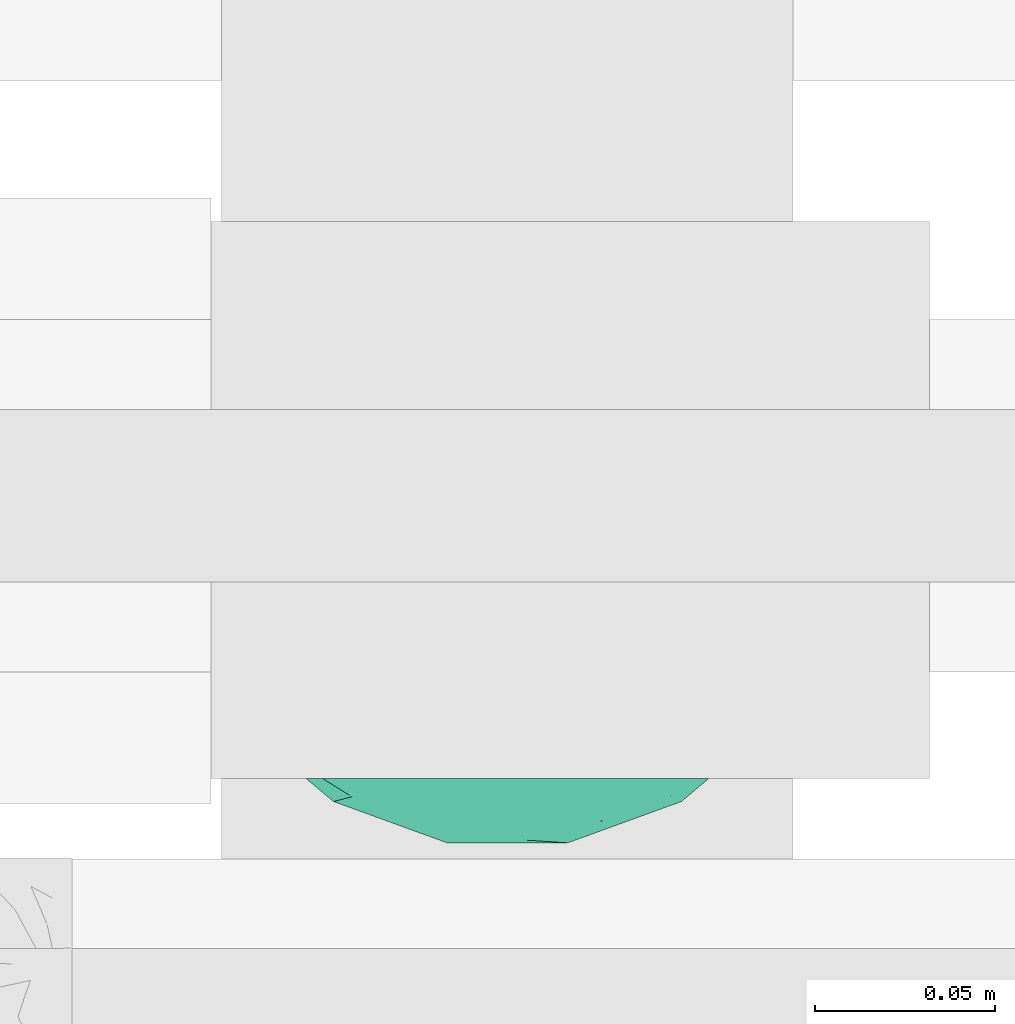
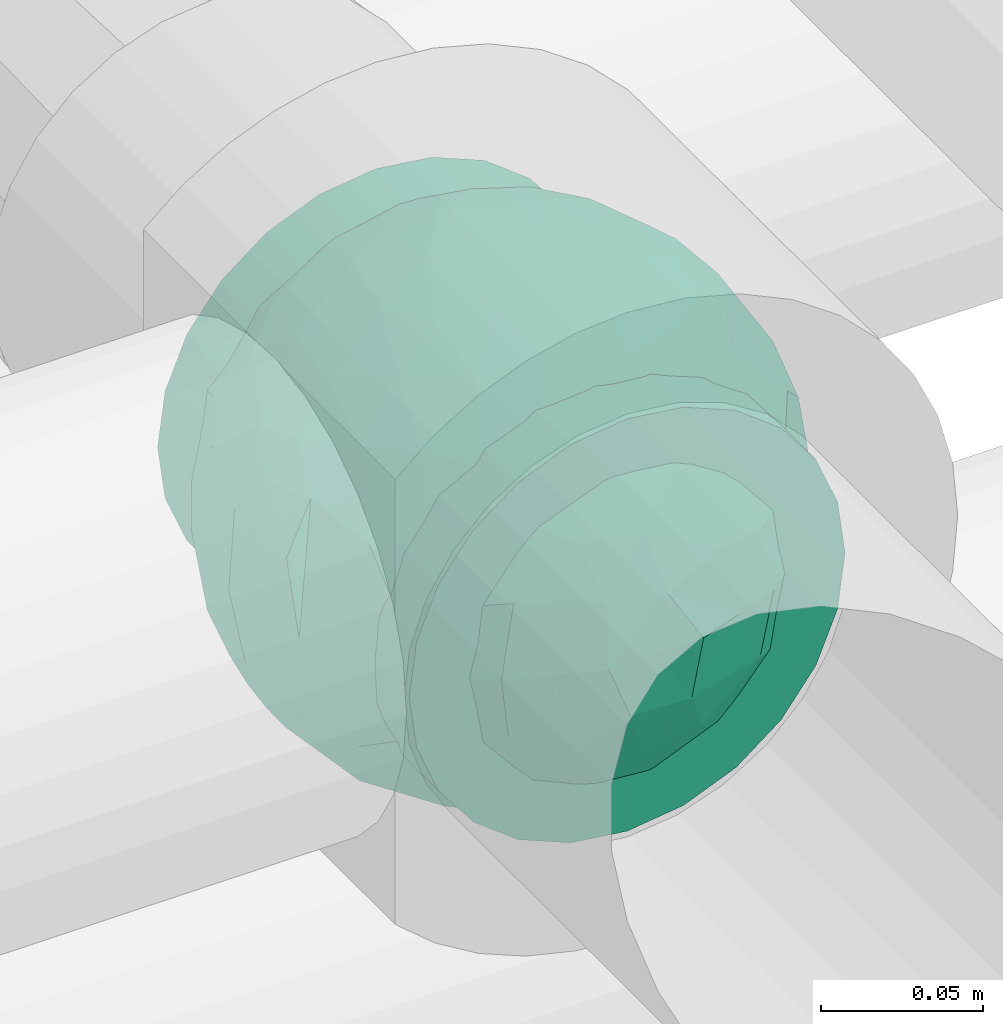
# One storey, part 66 of 93: 1 flow fitting.
"""IFC2X3 building model written with IfcOpenShell, lengths in millimetres."""

from ifc_helpers import new_model, entity, si_unit, converted_unit, derived_unit, direction, frame, origin, place, context, subcontext, project, spatial, faceted_brep, source, transform, mapped, material, material_list, type_object, type_shapes, element, save


model = new_model("IFC2X3")

# Units and contexts
model_context = context("Model", 3, precision=0.01, world=origin(), true_north=direction((6.12303176911189e-17, 1.0)))
body_context = subcontext(model_context, "Body", "Model", "MODEL_VIEW")
ifc_project = project(units=[si_unit("LENGTHUNIT", "METRE", prefix="MILLI"), si_unit("AREAUNIT", "SQUARE_METRE"), si_unit("VOLUMEUNIT", "CUBIC_METRE"), converted_unit("PLANEANGLEUNIT", "DEGREE", entity("IfcRatioMeasure", 0.0174532925199433), si_unit("PLANEANGLEUNIT", "RADIAN"), dimensions=[0, 0, 0, 0, 0, 0, 0]), si_unit("MASSUNIT", "GRAM", prefix="KILO"), derived_unit("MASSDENSITYUNIT", [(si_unit("MASSUNIT", "GRAM", prefix="KILO"), 1), (si_unit("LENGTHUNIT", "METRE"), -3)]), derived_unit("MOMENTOFINERTIAUNIT", [(si_unit("LENGTHUNIT", "METRE"), 4)]), si_unit("TIMEUNIT", "SECOND"), si_unit("FREQUENCYUNIT", "HERTZ"), si_unit("THERMODYNAMICTEMPERATUREUNIT", "DEGREE_CELSIUS"), derived_unit("THERMALTRANSMITTANCEUNIT", [(si_unit("MASSUNIT", "GRAM", prefix="KILO"), 1), (si_unit("THERMODYNAMICTEMPERATUREUNIT", "KELVIN"), -1), (si_unit("TIMEUNIT", "SECOND"), -3)]), derived_unit("VOLUMETRICFLOWRATEUNIT", [(si_unit("LENGTHUNIT", "METRE"), 3), (si_unit("TIMEUNIT", "SECOND"), -1)]), derived_unit("MASSFLOWRATEUNIT", [(si_unit("MASSUNIT", "GRAM", prefix="KILO"), 1), (si_unit("TIMEUNIT", "SECOND"), -1)]), derived_unit("ROTATIONALFREQUENCYUNIT", [(si_unit("TIMEUNIT", "SECOND"), -1)]), si_unit("ELECTRICCURRENTUNIT", "AMPERE"), si_unit("ELECTRICVOLTAGEUNIT", "VOLT"), si_unit("POWERUNIT", "WATT"), si_unit("FORCEUNIT", "NEWTON", prefix="KILO"), si_unit("ILLUMINANCEUNIT", "LUX"), si_unit("LUMINOUSFLUXUNIT", "LUMEN"), si_unit("LUMINOUSINTENSITYUNIT", "CANDELA"), derived_unit("USERDEFINED", [(si_unit("MASSUNIT", "GRAM", prefix="KILO"), -1), (si_unit("LENGTHUNIT", "METRE"), -2), (si_unit("TIMEUNIT", "SECOND"), 3), (si_unit("LUMINOUSFLUXUNIT", "LUMEN"), 1)]), derived_unit("LINEARVELOCITYUNIT", [(si_unit("LENGTHUNIT", "METRE"), 1), (si_unit("TIMEUNIT", "SECOND"), -1)]), si_unit("PRESSUREUNIT", "PASCAL"), derived_unit("USERDEFINED", [(si_unit("LENGTHUNIT", "METRE"), -2), (si_unit("MASSUNIT", "GRAM", prefix="KILO"), 1), (si_unit("TIMEUNIT", "SECOND"), -2)]), derived_unit("LINEARFORCEUNIT", [(si_unit("MASSUNIT", "GRAM", prefix="KILO"), 1), (si_unit("LENGTHUNIT", "METRE"), 1), (si_unit("TIMEUNIT", "SECOND"), -2), (si_unit("LENGTHUNIT", "METRE"), -1)]), derived_unit("PLANARFORCEUNIT", [(si_unit("MASSUNIT", "GRAM", prefix="KILO"), 1), (si_unit("LENGTHUNIT", "METRE"), 1), (si_unit("TIMEUNIT", "SECOND"), -2), (si_unit("LENGTHUNIT", "METRE"), -2)])], contexts=[model_context])

# Site, building, storey
site_placement = place(None, origin())
site = spatial("IfcSite", under=ifc_project, at=site_placement, CompositionType="ELEMENT")
building_placement = place(site_placement, origin())
building = spatial("IfcBuilding", under=site, at=building_placement, CompositionType="ELEMENT")
storey_placement = place(building_placement, frame((0.0, 0.0, -4200.0)))
storey = spatial("IfcBuildingStorey", under=building, at=storey_placement, CompositionType="ELEMENT", Elevation=-4200.0)

# Flow fitting
ifc_material_1 = material()
ifc_material_2 = material(Name="ADSK_")
ifc_material_list = material_list([ifc_material_1, ifc_material_2])
pipe_fitting_type = type_object("IfcPipeFittingType", Name="ADSK_2", PredefinedType="NOTDEFINED", material=ifc_material_list)
shared_shape = source(origin(), body_context, "Body", "Brep", [
    faceted_brep([(-77.5, 38.75, -67.12), (-77.5, 20.06, -74.86), (-77.5, 0.0, -77.5), (-77.5, -20.06, -74.86), (-77.5, -38.75, -67.12), (-77.5, -54.8, -54.8), (-77.5, -67.12, -38.75), (-77.5, -70.99, -29.4), (-77.5, -74.86, -20.06), (-77.5, -76.18, -10.03), (-77.5, -77.5, 0.0), (-77.5, -76.18, 10.03), (-77.5, -74.86, 20.06), (-77.5, -70.99, 29.4), (-77.5, -67.12, 38.75), (-77.5, -54.8, 54.8), (-77.5, -38.75, 67.12), (-77.5, -20.06, 74.86), (-77.5, 0.0, 77.5), (-77.5, 20.06, 74.86), (-77.5, 38.75, 67.12), (-77.5, 54.8, 54.8), (-77.5, 67.12, 38.75), (-77.5, 74.86, 20.06), (-77.5, 77.5, 0.0), (-77.5, 74.86, -20.06), (-77.5, 67.12, -38.75), (-77.5, 54.8, -54.8), (77.5, 0.0, -77.5), (77.5, 20.06, -74.86), (77.5, 38.75, -67.12), (77.5, 54.8, -54.8), (77.5, 67.12, -38.75), (77.5, 74.86, -20.06), (77.5, 77.5, 0.0), (77.5, 74.86, 20.06), (77.5, 67.12, 38.75), (77.5, 54.8, 54.8), (77.5, 38.75, 67.12), (77.5, 20.06, 74.86), (77.5, 0.0, 77.5), (77.5, -20.06, 74.86), (77.5, -38.75, 67.12), (77.5, -54.8, 54.8), (77.5, -67.12, 38.75), (77.5, -70.99, 29.4), (77.5, -74.86, 20.06), (77.5, -76.18, 10.03), (77.5, -77.5, 0.0), (77.5, -76.18, -10.03), (77.5, -74.86, -20.06), (77.5, -70.99, -29.4), (77.5, -67.12, -38.75), (77.5, -54.8, -54.8), (77.5, -38.75, -67.12), (77.5, -20.06, -74.86), (39.85, -76.08, 14.76), (41.18, -76.79, 7.38), (32.47, -72.49, 27.42), (36.16, -74.28, 21.09), (7.52, -65.24, 41.83), (42.5, -77.5, 0.0), (21.39, -68.25, 36.72), (14.46, -66.74, 39.28), (-21.4, -68.25, 36.72), (-32.48, -72.49, 27.41), (-39.86, -76.08, 14.76), (-41.18, -76.79, 7.38), (-42.5, -77.5, 0.0), (-36.17, -74.29, 21.08), (-14.46, -66.75, 39.27), (-7.53, -65.24, 41.83), (-0.01, -65.24, 41.83), (7.52, -65.24, -41.83), (-41.18, -76.79, -7.38), (21.39, -68.25, -36.72), (14.46, -66.74, -39.28), (41.18, -76.79, -7.38), (-39.86, -76.08, -14.76), (39.85, -76.08, -14.76), (36.16, -74.28, -21.09), (32.47, -72.49, -27.42), (-7.53, -65.24, -41.83), (-14.46, -66.75, -39.27), (-21.4, -68.25, -36.72), (-32.48, -72.49, -27.41), (-0.01, -65.24, -41.83), (-36.17, -74.29, -21.08), (11.0, -82.5, -41.05), (21.25, -82.5, -36.81), (30.05, -82.5, -30.05), (36.81, -82.5, -21.25), (41.05, -82.5, -11.0), (41.78, -82.5, -5.5), (42.5, -82.5, 0.0), (41.78, -82.5, 5.5), (41.05, -82.5, 11.0), (36.81, -82.5, 21.25), (30.05, -82.5, 30.05), (21.25, -82.5, 36.81), (11.0, -82.5, 41.05), (0.0, -82.5, 42.5), (-11.0, -82.5, 41.05), (-21.25, -82.5, 36.81), (-30.05, -82.5, 30.05), (-36.81, -82.5, 21.25), (-41.05, -82.5, 11.0), (-41.78, -82.5, 5.5), (-42.5, -82.5, 0.0), (-41.78, -82.5, -5.5), (-41.05, -82.5, -11.0), (-36.81, -82.5, -21.25), (-30.05, -82.5, -30.05), (-21.25, -82.5, -36.81), (-11.0, -82.5, -41.05), (0.0, -82.5, -42.5)], [[[0, 1, 2, 3, 4, 5, 6, 7, 8, 9, 10, 11, 12, 13, 14, 15, 16, 17, 18, 19, 20, 21, 22, 23, 24, 25, 26, 27]], [[28, 29, 30, 31, 32, 33, 34, 35, 36, 37, 38, 39, 40, 41, 42, 43, 44, 45, 46, 47, 48, 49, 50, 51, 52, 53, 54, 55]], [[47, 46, 56]], [[48, 47, 57]], [[46, 58, 59, 56]], [[44, 43, 60]], [[48, 57, 61]], [[58, 45, 62]], [[44, 60, 63, 62]], [[47, 56, 57]], [[43, 15, 60]], [[62, 45, 44]], [[64, 13, 65]], [[66, 11, 67]], [[68, 67, 10]], [[12, 66, 69, 65]], [[14, 64, 70, 71]], [[58, 46, 45]], [[14, 13, 64]], [[14, 71, 15]], [[65, 13, 12]], [[15, 71, 72, 60]], [[10, 67, 11]], [[66, 12, 11]], [[43, 42, 16, 15]], [[18, 17, 41, 40]], [[17, 16, 42, 41]], [[19, 18, 40, 39]], [[36, 35, 23, 22]], [[21, 20, 38, 37]], [[22, 21, 37, 36]], [[39, 38, 20, 19]], [[24, 23, 35, 34]], [[26, 25, 33, 32]], [[25, 24, 34, 33]], [[27, 26, 32, 31]], [[28, 55, 3, 2]], [[1, 0, 30, 29]], [[2, 1, 29, 28]], [[31, 30, 0, 27]], [[4, 3, 55, 54]], [[54, 53, 5, 4]], [[53, 52, 73]], [[10, 74, 68]], [[52, 75, 76, 73]], [[51, 75, 52]], [[53, 73, 5]], [[61, 77, 48]], [[9, 78, 74]], [[50, 79, 80, 81]], [[79, 49, 77]], [[75, 51, 81]], [[50, 81, 51]], [[6, 82, 83, 84]], [[85, 8, 7]], [[6, 5, 82]], [[85, 7, 84]], [[5, 73, 86, 82]], [[8, 85, 87, 78]], [[79, 50, 49]], [[78, 9, 8]], [[74, 10, 9]], [[48, 77, 49]], [[7, 6, 84]], [[88, 89, 90, 91, 92, 93, 94, 95, 96, 97, 98, 99, 100, 101, 102, 103, 104, 105, 106, 107, 108, 109, 110, 111, 112, 113, 114, 115]], [[107, 106, 67]], [[65, 105, 104]], [[106, 105, 66]], [[104, 103, 64]], [[61, 95, 94]], [[107, 68, 108]], [[66, 105, 65, 69]], [[70, 64, 103]], [[64, 65, 104]], [[101, 60, 72, 71]], [[102, 71, 70]], [[102, 70, 103]], [[68, 107, 67]], [[57, 96, 95]], [[60, 101, 100]], [[101, 71, 102]], [[58, 98, 97]], [[99, 98, 62]], [[56, 97, 96]], [[99, 63, 100]], [[98, 58, 62]], [[106, 66, 67]], [[63, 60, 100]], [[96, 57, 56]], [[59, 58, 97, 56]], [[95, 61, 57]], [[63, 99, 62]], [[93, 92, 77]], [[81, 91, 90]], [[92, 91, 79]], [[90, 89, 75]], [[68, 109, 108]], [[93, 61, 94]], [[79, 91, 81, 80]], [[76, 75, 89]], [[75, 81, 90]], [[115, 82, 86, 73]], [[83, 113, 84]], [[88, 76, 89]], [[88, 73, 76]], [[61, 93, 77]], [[82, 115, 114]], [[115, 73, 88]], [[111, 85, 112]], [[74, 110, 109]], [[113, 112, 84]], [[78, 111, 110]], [[113, 83, 114]], [[112, 85, 84]], [[92, 79, 77]], [[110, 74, 78]], [[87, 85, 111, 78]], [[109, 68, 74]], [[83, 82, 114]]]),
    faceted_brep([(74.09, -36.62, -50.54), (86.5, -25.35, -35.5), (82.61, -45.18, -22.81), (-16.75, -33.7, -89.27), (0.0, -42.78, -86.92), (-23.87, -49.97, -79.49), (73.94, -14.61, -60.86), (53.84, -28.63, -75.28), (-16.57, 93.95, 0.0), (-18.09, 86.11, -40.53), (-32.84, 86.73, -28.0), (-44.04, -10.15, -85.69), (-19.2, 4.88, -94.83), (-22.92, -15.62, -92.82), (89.65, 32.63, 0.0), (82.61, 44.34, -24.37), (83.9, 48.44, 0.0), (47.7, -82.62, 0.0), (60.26, -69.94, -29.38), (62.27, -74.21, 0.0), (95.4, 0.0, 0.0), (95.4, -16.82, 0.0), (94.13, -8.44, -21.26), (93.14, 13.95, -22.71), (95.4, 16.82, 0.0), (76.54, 8.21, -58.81), (74.09, 36.62, -50.54), (84.96, 22.7, -40.64), (28.25, -36.42, -85.21), (19.67, -61.78, -71.98), (-67.45, 51.53, -46.69), (-45.73, 54.97, -65.36), (-59.68, 42.12, -63.64), (47.7, 82.62, 0.0), (62.27, 74.21, 0.0), (59.48, 63.11, -43.18), (-48.12, -74.69, -38.62), (-33.13, -91.03, 0.0), (-47.7, -82.62, 0.0), (72.35, 57.3, -29.46), (60.01, 43.15, -62.62), (62.52, -52.48, -52.18), (45.73, -54.97, -65.36), (-62.27, -74.21, 0.0), (-73.08, -61.32, 0.0), (-72.41, -59.62, -24.21), (7.26, -81.07, -52.53), (35.35, -68.17, -59.06), (27.87, -86.63, -33.22), (-74.09, -36.62, -50.54), (-84.35, -21.79, -42.37), (-76.59, -6.33, -58.98), (61.55, 0.0, -74.81), (-61.55, 0.0, -74.81), (-79.37, 15.54, -53.33), (-95.4, -16.82, 0.0), (-92.58, -16.52, -23.25), (-89.65, -32.63, 0.0), (63.81, 22.67, -69.28), (-18.69, 68.07, -66.35), (-42.94, 76.94, -40.26), (-74.09, 36.62, -50.54), (-43.64, 36.19, -78.55), (-65.1, 21.71, -68.38), (44.46, 15.06, -84.74), (-65.04, -21.76, -68.42), (-94.63, 4.93, -20.13), (-87.93, 0.0, -40.67), (-89.65, 32.63, 0.0), (-89.27, 26.35, -26.85), (27.96, 84.78, -37.61), (7.26, 81.07, -52.53), (1.19, 92.73, -28.0), (3.41, -92.84, -27.46), (-8.28, -95.41, 0.0), (-11.9, -93.14, -23.83), (73.08, 61.32, 0.0), (87.93, 0.0, -40.67), (73.08, -61.32, 0.0), (83.9, -48.44, 0.0), (-73.08, 61.32, 0.0), (-82.24, 45.34, -23.77), (-83.9, 48.44, 0.0), (-63.57, -59.47, -42.5), (-45.73, -54.97, -65.36), (-82.58, -43.28, -26.32), (29.11, 48.1, -78.89), (45.73, 54.97, -65.36), (44.58, 36.0, -78.11), (-61.2, 65.56, -36.61), (-6.93, -65.5, -71.03), (30.56, -5.14, -91.79), (9.54, -19.86, -94.34), (0.0, 12.89, -96.01), (47.81, -10.83, -83.56), (89.65, -32.63, 0.0), (44.95, 76.64, -38.61), (33.13, 91.03, 0.0), (28.53, 69.09, -61.62), (-51.45, 14.65, -80.76), (22.17, 26.71, -90.44), (33.13, -91.03, 0.0), (44.95, -76.64, -38.61), (72.35, -57.3, -29.46), (16.57, -93.95, 0.0), (-15.25, 22.47, -92.99), (2.72, 32.92, -91.07), (8.92, 50.75, -82.03), (9.42, 67.57, -68.78), (16.57, 93.95, 0.0), (-5.45, -87.35, -41.54), (8.28, -95.41, 0.0), (0.0, -96.88, 0.0), (-24.34, -90.45, -24.71), (-25.14, -82.23, -44.62), (-16.57, -93.95, 0.0), (-9.92, -78.26, -56.23), (-30.26, -67.58, -62.46), (-40.87, -32.58, -81.57), (-34.66, 17.97, -88.66), (-59.69, -42.16, -63.59), (-16.8, 39.61, -86.8), (-28.19, 53.95, -75.36), (-10.32, 55.25, -78.9), (-57.91, -73.21, -25.92), (-83.9, -48.44, 0.0), (-95.4, 0.0, 0.0), (-95.4, 16.82, 0.0), (-72.43, 58.81, -26.08), (-62.27, 74.21, 0.0), (-47.7, 82.62, 0.0), (-33.13, 91.03, 0.0), (0.0, 96.87, 0.0), (-74.09, -36.62, 50.54), (-86.5, -25.35, 35.5), (-82.61, -45.18, 22.81), (16.75, -33.7, 89.27), (0.0, -42.78, 86.92), (23.87, -49.97, 79.49), (-73.94, -14.61, 60.86), (-53.84, -28.63, 75.28), (18.09, 86.11, 40.53), (32.84, 86.73, 28.0), (44.04, -10.15, 85.69), (19.2, 4.88, 94.83), (22.92, -15.62, 92.82), (-82.61, 44.34, 24.37), (-60.26, -69.94, 29.38), (-94.13, -8.44, 21.26), (-93.14, 13.95, 22.71), (-76.54, 8.21, 58.81), (-74.09, 36.62, 50.54), (-84.96, 22.7, 40.64), (-28.25, -36.42, 85.21), (-19.67, -61.78, 71.98), (67.45, 51.53, 46.69), (45.73, 54.97, 65.36), (59.68, 42.12, 63.64), (-28.53, 69.09, 61.62), (-45.73, 54.97, 65.36), (-29.11, 48.1, 78.89), (48.12, -74.69, 38.62), (-59.48, 63.11, 43.18), (-72.35, 57.3, 29.46), (-60.01, 43.15, 62.62), (-35.35, -68.17, 59.06), (-7.26, -81.07, 52.53), (72.41, -59.62, 24.21), (-3.41, -92.84, 27.46), (74.09, -36.62, 50.54), (84.35, -21.79, 42.37), (76.59, -6.33, 58.98), (-61.55, 0.0, 74.81), (61.55, 0.0, 74.81), (79.37, 15.54, 53.33), (92.58, -16.52, 23.25), (-63.81, 22.67, 69.28), (18.69, 68.07, 66.35), (42.94, 76.94, 40.26), (74.09, 36.62, 50.54), (43.64, 36.19, 78.55), (65.1, 21.71, 68.38), (-44.46, 15.06, 84.74), (65.04, -21.76, 68.42), (94.63, 4.93, 20.13), (87.93, 0.0, 40.67), (89.27, 26.35, 26.85), (-27.96, 84.78, 37.61), (-7.26, 81.07, 52.53), (-1.19, 92.73, 28.0), (11.9, -93.14, 23.83), (-87.93, 0.0, 40.67), (82.24, 45.34, 23.77), (63.57, -59.47, 42.5), (45.73, -54.97, 65.36), (82.58, -43.28, 26.32), (-44.58, 36.0, 78.11), (61.2, 65.56, 36.61), (25.14, -82.23, 44.62), (5.45, -87.35, 41.54), (24.34, -90.45, 24.71), (6.93, -65.5, 71.03), (-30.56, -5.14, 91.79), (-9.54, -19.86, 94.34), (0.0, 12.89, 96.01), (-47.81, -10.83, 83.56), (-44.95, 76.64, 38.61), (51.45, 14.65, 80.76), (-62.52, -52.48, 52.18), (-45.73, -54.97, 65.36), (-22.17, 26.71, 90.44), (-44.95, -76.64, 38.61), (-72.35, -57.3, 29.46), (-27.87, -86.63, 33.22), (15.25, 22.47, 92.99), (-2.72, 32.92, 91.07), (-8.92, 50.75, 82.03), (-9.42, 67.57, 68.78), (9.92, -78.26, 56.23), (30.26, -67.58, 62.46), (40.87, -32.58, 81.57), (34.66, 17.97, 88.66), (59.69, -42.16, 63.59), (16.8, 39.61, 86.8), (28.19, 53.95, 75.36), (10.32, 55.25, 78.9), (57.91, -73.21, 25.92), (72.43, 58.81, 26.08)], [[[0, 1, 2]], [[3, 4, 5]], [[6, 0, 7]], [[8, 9, 10]], [[11, 12, 13]], [[14, 15, 16]], [[17, 18, 19]], [[20, 21, 22]], [[23, 24, 20]], [[25, 26, 27]], [[4, 28, 29]], [[30, 31, 32]], [[33, 34, 35]], [[36, 37, 38]], [[35, 39, 40]], [[41, 18, 42]], [[43, 44, 45]], [[46, 47, 48]], [[49, 50, 51]], [[52, 25, 6]], [[53, 51, 54]], [[55, 56, 57]], [[26, 25, 58]], [[59, 31, 60]], [[32, 61, 30]], [[62, 63, 32]], [[52, 64, 58]], [[51, 65, 49]], [[56, 66, 67]], [[66, 68, 69]], [[70, 71, 72]], [[73, 74, 75]], [[6, 7, 52]], [[20, 22, 23]], [[76, 39, 34]], [[15, 26, 39]], [[1, 77, 22]], [[78, 2, 79]], [[61, 54, 69]], [[80, 81, 82]], [[36, 83, 84]], [[85, 56, 50]], [[86, 87, 88]], [[60, 31, 89]], [[48, 73, 46]], [[4, 29, 90]], [[91, 92, 93]], [[7, 94, 52]], [[77, 23, 22]], [[95, 79, 2]], [[0, 6, 1]], [[1, 22, 95]], [[1, 95, 2]], [[27, 23, 77]], [[15, 14, 23]], [[25, 27, 77]], [[15, 76, 16]], [[40, 39, 26]], [[39, 76, 15]], [[96, 97, 33]], [[70, 98, 71]], [[39, 35, 34]], [[87, 86, 98]], [[77, 1, 6]], [[25, 52, 58]], [[62, 99, 63]], [[26, 15, 27]], [[6, 25, 77]], [[0, 41, 7]], [[42, 28, 7]], [[92, 91, 28]], [[94, 28, 91]], [[88, 87, 40]], [[52, 94, 64]], [[40, 26, 58]], [[100, 91, 93]], [[88, 40, 58]], [[22, 21, 95]], [[101, 102, 17]], [[103, 78, 19]], [[41, 0, 103]], [[18, 102, 42]], [[101, 48, 102]], [[101, 104, 48]], [[29, 28, 42]], [[28, 4, 92]], [[102, 47, 42]], [[90, 29, 46]], [[88, 58, 64]], [[40, 87, 35]], [[87, 96, 35]], [[33, 35, 96]], [[100, 64, 91]], [[88, 64, 100]], [[12, 105, 93]], [[98, 96, 87]], [[106, 100, 93]], [[86, 100, 107]], [[100, 86, 88]], [[98, 108, 71]], [[108, 86, 107]], [[109, 70, 72]], [[70, 109, 97]], [[96, 98, 70]], [[97, 96, 70]], [[78, 103, 2]], [[0, 2, 103]], [[41, 103, 18]], [[7, 41, 42]], [[19, 18, 103]], [[102, 18, 17]], [[75, 110, 73]], [[73, 104, 111, 112]], [[113, 114, 110]], [[115, 75, 74]], [[36, 114, 37]], [[90, 5, 4]], [[73, 48, 104]], [[47, 46, 29]], [[46, 116, 90]], [[5, 117, 84]], [[90, 116, 117]], [[118, 13, 3]], [[118, 5, 84]], [[11, 119, 12]], [[65, 120, 49]], [[11, 13, 118]], [[63, 53, 54]], [[121, 122, 123]], [[90, 117, 5]], [[49, 120, 83]], [[117, 36, 84]], [[36, 117, 114]], [[43, 45, 124]], [[38, 124, 36]], [[83, 124, 45]], [[85, 125, 57]], [[125, 85, 44]], [[45, 49, 83]], [[66, 55, 126, 127]], [[57, 56, 85]], [[56, 67, 50]], [[51, 50, 67]], [[85, 50, 49]], [[54, 51, 67]], [[51, 53, 65]], [[69, 54, 67]], [[54, 61, 63]], [[69, 67, 66]], [[128, 129, 89]], [[11, 65, 53]], [[120, 118, 84]], [[32, 63, 61]], [[99, 53, 63]], [[118, 120, 65]], [[83, 120, 84]], [[129, 128, 80]], [[62, 32, 31]], [[60, 130, 131]], [[130, 60, 89]], [[9, 71, 59]], [[10, 60, 131]], [[108, 59, 71]], [[71, 9, 72]], [[62, 121, 119]], [[122, 59, 123]], [[62, 119, 99]], [[62, 31, 122]], [[106, 107, 100]], [[44, 85, 45]], [[49, 45, 85]], [[55, 66, 56]], [[62, 122, 121]], [[89, 129, 130]], [[65, 11, 118]], [[11, 53, 99]], [[80, 128, 81]], [[30, 128, 89]], [[81, 61, 69]], [[61, 81, 128]], [[82, 81, 69]], [[10, 59, 60]], [[72, 8, 132]], [[8, 72, 9]], [[109, 72, 132]], [[3, 92, 4]], [[92, 13, 12]], [[23, 27, 15]], [[14, 24, 23]], [[11, 99, 119]], [[128, 30, 61]], [[31, 30, 89]], [[28, 94, 7]], [[64, 94, 91]], [[48, 47, 102]], [[29, 42, 47]], [[105, 106, 93]], [[123, 106, 121]], [[86, 108, 98]], [[108, 107, 123]], [[73, 112, 74]], [[113, 75, 115]], [[114, 116, 110]], [[115, 37, 113]], [[37, 114, 113]], [[46, 73, 110]], [[117, 116, 114]], [[110, 75, 113]], [[46, 110, 116]], [[118, 3, 5]], [[92, 3, 13]], [[105, 119, 121]], [[92, 12, 93]], [[119, 105, 12]], [[106, 105, 121]], [[43, 124, 38]], [[83, 36, 124]], [[68, 66, 127]], [[68, 82, 69]], [[31, 59, 122]], [[108, 123, 59]], [[106, 123, 107]], [[8, 10, 131]], [[59, 10, 9]], [[133, 134, 135]], [[136, 137, 138]], [[139, 133, 140]], [[109, 141, 142]], [[143, 144, 145]], [[68, 146, 82]], [[38, 147, 43]], [[148, 126, 55]], [[149, 127, 126]], [[150, 151, 152]], [[137, 153, 154]], [[155, 156, 157]], [[158, 159, 160]], [[161, 101, 17]], [[162, 163, 164]], [[154, 165, 166]], [[19, 78, 167]], [[168, 115, 74, 112]], [[169, 170, 171]], [[172, 150, 139]], [[173, 171, 174]], [[21, 175, 95]], [[151, 150, 176]], [[177, 156, 178]], [[157, 179, 155]], [[180, 181, 157]], [[172, 182, 176]], [[171, 183, 169]], [[175, 184, 185]], [[186, 24, 14, 16]], [[187, 188, 189]], [[168, 111, 190]], [[139, 140, 172]], [[126, 148, 149]], [[80, 163, 129]], [[146, 151, 163]], [[134, 191, 148]], [[44, 135, 125]], [[179, 174, 186]], [[76, 192, 16]], [[161, 193, 194]], [[195, 175, 170]], [[160, 159, 196]], [[178, 156, 197]], [[198, 199, 200]], [[137, 154, 201]], [[202, 203, 204]], [[140, 205, 172]], [[134, 133, 139]], [[125, 135, 57]], [[148, 191, 149]], [[134, 148, 57]], [[134, 57, 135]], [[152, 149, 191]], [[146, 68, 149]], [[150, 152, 191]], [[146, 80, 82]], [[164, 163, 151]], [[163, 80, 146]], [[162, 130, 129]], [[130, 206, 131]], [[163, 162, 129]], [[158, 188, 187]], [[191, 134, 139]], [[150, 172, 176]], [[180, 207, 181]], [[151, 146, 152]], [[139, 150, 191]], [[133, 208, 140]], [[209, 153, 140]], [[203, 202, 153]], [[205, 153, 202]], [[196, 159, 164]], [[172, 205, 182]], [[164, 151, 176]], [[210, 202, 204]], [[196, 164, 176]], [[148, 55, 57]], [[38, 37, 211]], [[212, 44, 43]], [[208, 133, 212]], [[147, 211, 209]], [[165, 213, 166]], [[209, 208, 147]], [[154, 153, 209]], [[153, 137, 203]], [[211, 165, 209]], [[201, 154, 166]], [[196, 176, 182]], [[164, 159, 162]], [[159, 206, 162]], [[130, 162, 206]], [[210, 182, 202]], [[196, 182, 210]], [[144, 214, 204]], [[158, 206, 159]], [[215, 210, 204]], [[160, 210, 216]], [[210, 160, 196]], [[158, 217, 188]], [[217, 160, 216]], [[8, 187, 189]], [[187, 8, 131]], [[206, 158, 187]], [[131, 206, 187]], [[44, 212, 135]], [[133, 135, 212]], [[208, 212, 147]], [[140, 208, 209]], [[43, 147, 212]], [[211, 147, 38]], [[199, 168, 190]], [[213, 115, 168]], [[213, 168, 166]], [[104, 190, 111]], [[161, 198, 101]], [[201, 138, 137]], [[37, 115, 213]], [[211, 37, 213]], [[166, 218, 201]], [[138, 219, 194]], [[201, 218, 219]], [[220, 145, 136]], [[220, 138, 194]], [[143, 221, 144]], [[183, 222, 169]], [[143, 145, 220]], [[181, 173, 174]], [[223, 224, 225]], [[201, 219, 138]], [[169, 222, 193]], [[219, 161, 194]], [[161, 219, 198]], [[19, 167, 226]], [[17, 226, 161]], [[193, 226, 167]], [[195, 79, 95]], [[79, 195, 78]], [[167, 169, 193]], [[184, 21, 20, 24]], [[95, 175, 195]], [[175, 185, 170]], [[171, 170, 185]], [[195, 170, 169]], [[174, 171, 185]], [[171, 173, 183]], [[186, 174, 185]], [[174, 179, 181]], [[186, 185, 184]], [[227, 34, 197]], [[143, 183, 173]], [[222, 220, 194]], [[157, 181, 179]], [[207, 173, 181]], [[220, 222, 183]], [[193, 222, 194]], [[34, 227, 76]], [[180, 157, 156]], [[178, 33, 97]], [[33, 178, 197]], [[141, 188, 177]], [[142, 178, 97]], [[217, 177, 188]], [[188, 141, 189]], [[180, 223, 221]], [[224, 177, 225]], [[180, 221, 207]], [[180, 156, 224]], [[215, 216, 210]], [[78, 195, 167]], [[169, 167, 195]], [[21, 184, 175]], [[186, 184, 24]], [[197, 34, 33]], [[183, 143, 220]], [[143, 173, 207]], [[76, 227, 192]], [[155, 227, 197]], [[192, 179, 186]], [[179, 192, 227]], [[16, 192, 186]], [[142, 177, 178]], [[189, 109, 132]], [[109, 189, 141]], [[8, 189, 132]], [[136, 203, 137]], [[203, 145, 144]], [[149, 152, 146]], [[68, 127, 149]], [[143, 207, 221]], [[227, 155, 179]], [[156, 155, 197]], [[153, 205, 140]], [[182, 205, 202]], [[213, 165, 211]], [[154, 209, 165]], [[214, 215, 204]], [[225, 215, 223]], [[160, 217, 158]], [[217, 216, 225]], [[168, 112, 111]], [[200, 190, 104]], [[198, 218, 199]], [[104, 101, 200]], [[101, 198, 200]], [[166, 168, 199]], [[219, 218, 198]], [[199, 190, 200]], [[166, 199, 218]], [[220, 136, 138]], [[203, 136, 145]], [[214, 221, 223]], [[203, 144, 204]], [[221, 214, 144]], [[215, 214, 223]], [[19, 226, 17]], [[193, 161, 226]], [[180, 224, 223]], [[156, 177, 224]], [[217, 225, 177]], [[215, 225, 216]], [[109, 142, 97]], [[177, 142, 141]]]),
])
type_shapes(pipe_fitting_type, [shared_shape])
flow_fitting_placement = place(storey_placement, frame((24179.3, 8859.98, 3000.76), z_axis=(0.0, 0.0, -1.0), x_axis=(0.0, 1.0, 0.0)))
element("IfcFlowFitting", 1, at=flow_fitting_placement, inside=storey, type_object=pipe_fitting_type, material=ifc_material_list, Name="ADSK_2", ObjectType="ADSK_2", context=body_context, shape_type="MappedRepresentation", body=[
    mapped(shared_shape, transform((0.0, 0.0, 0.0), scale=1.0)),
])

save(model, "model.ifc")
